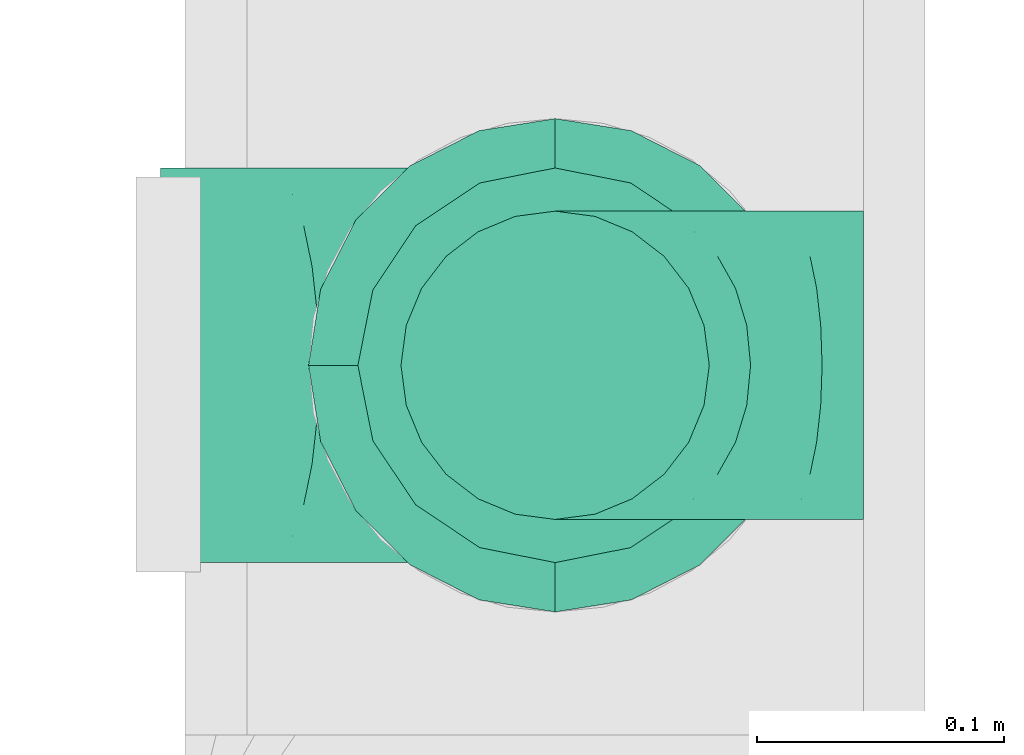
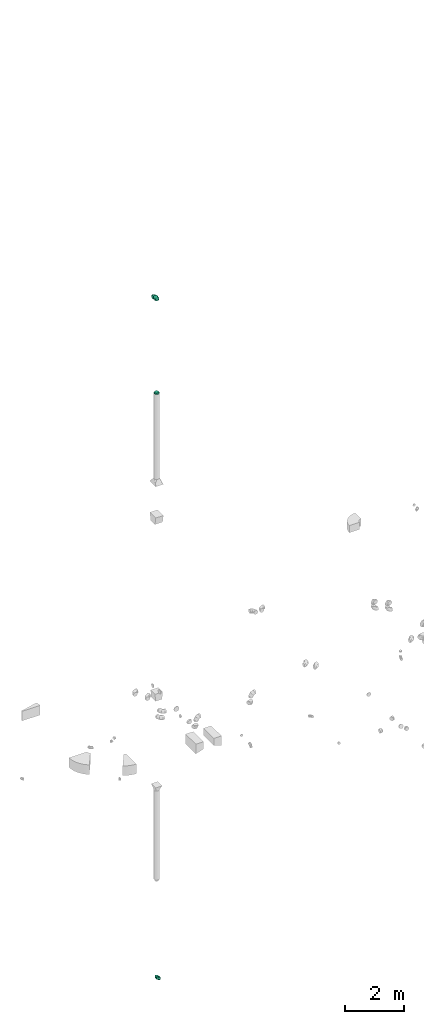
# One storey, part 4 of 32: 3 flow fittings.
"""IFC2X3 building model written with IfcOpenShell, lengths in millimetres."""

import ifcopenshell
import ifcopenshell.guid

model = None  # the IFC model being written
_history = None  # IfcOwnerHistory: only IFC2X3 demands one
_inside = {}  # id of a spatial element -> (the spatial element, [elements in it])
_under = {}  # id of a project, library or spatial element -> (it, [spatial elements below it])
_declared = {}  # id of a project -> (the project, [libraries it declares])
_typed = {}  # id of a type object -> (the type object, [elements of that type])
_made_of = {}  # id of a material, layer set ... -> (it, [elements and type objects made of it])


def new_model(schema):
    """Start an empty IFC model of exactly this schema.

    Asked for "IFC4X3", IfcOpenShell would pick the latest addendum, in which some entities
    have other attributes; the version numbers below select the first issue.
    IFC2X3 requires an IfcOwnerHistory on every rooted entity: one is made here for all.
    """
    global model, _history
    if schema == "IFC4X3":
        model = ifcopenshell.file(schema_version=(4, 3, 0, 0))
    else:
        model = ifcopenshell.file(schema=schema)
    _inside.clear()
    _under.clear()
    _declared.clear()
    _typed.clear()
    _made_of.clear()
    _history = None
    if model.schema == "IFC2X3":
        org = make("IfcOrganization", Name="unknown")
        user = make(
            "IfcPersonAndOrganization",
            ThePerson=make("IfcPerson", FamilyName="unknown"),
            TheOrganization=org,
        )
        app = make(
            "IfcApplication",
            ApplicationDeveloper=org,
            Version="unknown",
            ApplicationFullName="unknown",
            ApplicationIdentifier="unknown",
        )
        _history = make(
            "IfcOwnerHistory",
            OwningUser=user,
            OwningApplication=app,
            ChangeAction="ADDED",
            CreationDate=0,
        )
    return model


def make(cls, **values):
    """One entity of the class cls with the attributes given. An attribute that is None is left unset."""
    return model.create_entity(
        cls, **{name: value for name, value in values.items() if value is not None}
    )


def entity(cls, *values):
    """Any entity or typed value of the class cls, its attributes in the order of the schema. None: left unset."""
    e = model.create_entity(cls)
    for i, value in enumerate(values):
        if value is not None:
            e[i] = value
    return e


def rooted(cls, **values):
    """An entity with a GlobalId (a new one), such as an element, a storey or a relation."""
    return make(cls, GlobalId=ifcopenshell.guid.new(), OwnerHistory=_history, **values)


def si_unit(unit_type, name, prefix=None):
    """IfcSIUnit, for example si_unit("LENGTHUNIT", "METRE", prefix="MILLI")."""
    return make("IfcSIUnit", UnitType=unit_type, Prefix=prefix, Name=name)


def converted_unit(unit_type, name, factor, base, dimensions=None, offset=None):
    """IfcConversionBasedUnit, such as the inch: factor (a typed value) times the base unit."""
    return make(
        "IfcConversionBasedUnit"
        if offset is None
        else "IfcConversionBasedUnitWithOffset",
        ConversionOffset=offset,
        Dimensions=None
        if dimensions is None
        else entity("IfcDimensionalExponents", *dimensions),
        UnitType=unit_type,
        Name=name,
        ConversionFactor=make(
            "IfcMeasureWithUnit", ValueComponent=factor, UnitComponent=base
        ),
    )


def derived_unit(unit_type, elements):
    """IfcDerivedUnit: a product of units, each with its exponent."""
    return make(
        "IfcDerivedUnit",
        Elements=[
            make("IfcDerivedUnitElement", Unit=unit, Exponent=power)
            for unit, power in elements
        ],
        UnitType=unit_type,
    )


def assignment(units):
    """IfcUnitAssignment: the units of a project."""
    return None if units is None else make("IfcUnitAssignment", Units=units)


def point(xyz):
    """IfcCartesianPoint."""
    return None if xyz is None else make("IfcCartesianPoint", Coordinates=xyz)


def direction(xyz):
    """IfcDirection."""
    return None if xyz is None else make("IfcDirection", DirectionRatios=xyz)


def frame(location, z_axis=None, x_axis=None):
    """IfcAxis2Placement3D, a coordinate frame: its origin and axes. An axis left out is left unset."""
    return make(
        "IfcAxis2Placement3D",
        Location=point(location),
        Axis=direction(z_axis),
        RefDirection=direction(x_axis),
    )


def origin():
    """The frame at (0, 0, 0) with its axes left unset."""
    return frame((0.0, 0.0, 0.0))


def place(relative_to, where):
    """IfcLocalPlacement: puts the frame where relative to a parent placement (None: the world)."""
    return make(
        "IfcLocalPlacement", PlacementRelTo=relative_to, RelativePlacement=where
    )


def context(
    kind, dimensions, precision=None, world=None, true_north=None, identifier=None
):
    """IfcGeometricRepresentationContext, for example the 3D "Model" context."""
    return make(
        "IfcGeometricRepresentationContext",
        ContextIdentifier=identifier,
        ContextType=kind,
        CoordinateSpaceDimension=dimensions,
        Precision=precision,
        WorldCoordinateSystem=world,
        TrueNorth=true_north,
    )


def subcontext(parent, identifier, kind, view, scale=None):
    """IfcGeometricRepresentationSubContext, for example "Body" below "Model"."""
    return make(
        "IfcGeometricRepresentationSubContext",
        ContextIdentifier=identifier,
        ContextType=kind,
        ParentContext=parent,
        TargetScale=scale,
        TargetView=view,
    )


def project(units=None, contexts=None):
    """IfcProject with its units and contexts."""
    return rooted(
        "IfcProject",
        Name="project",
        RepresentationContexts=contexts,
        UnitsInContext=assignment(units),
    )


def spatial(cls, under=None, at=None, **own):
    """A site, building, storey or space (cls), placed at a placement, below another one or the project."""
    s = rooted(cls, ObjectPlacement=at, **own)
    if under is not None:
        _under.setdefault(under.id(), (under, []))[1].append(s)
    return s


def faces_of(points, faces, orient=None, outer=None):
    """IfcFace entities. A face is a list of loops; a loop is a list of indices into points, from 0.

    orient and outer hold one flag for each loop. By default every Orientation is true, the
    first loop of a face is its IfcFaceOuterBound and the others are IfcFaceBound.
    """
    made = []
    for i, loops in enumerate(faces):
        bounds = []
        for j, loop in enumerate(loops):
            is_outer = j == 0 if outer is None else outer[i][j]
            bounds.append(
                make(
                    "IfcFaceOuterBound" if is_outer else "IfcFaceBound",
                    Bound=make("IfcPolyLoop", Polygon=[points[k] for k in loop]),
                    Orientation=True if orient is None else orient[i][j],
                )
            )
        made.append(make("IfcFace", Bounds=bounds))
    return made


def faceted_brep(points, faces, orient=None, outer=None, voids=None):
    """IfcFacetedBrep: a solid bounded by flat faces; with voids (closed shells), ...WithVoids."""
    shared = [point(p) for p in points]
    hull = make("IfcClosedShell", CfsFaces=faces_of(shared, faces, orient, outer))
    if voids is None:
        return make("IfcFacetedBrep", Outer=hull)
    return make(
        "IfcFacetedBrepWithVoids",
        Outer=hull,
        Voids=[
            make(cls, CfsFaces=faces_of(shared, fs, o, b)) for cls, fs, o, b in voids
        ],
    )


def shape(context_of_items, identifier, shape_type, items):
    """IfcShapeRepresentation: the items that make up one representation, for example the "Body"."""
    return make(
        "IfcShapeRepresentation",
        ContextOfItems=context_of_items,
        RepresentationIdentifier=identifier,
        RepresentationType=shape_type,
        Items=items,
    )


def source(mapping_origin, context_of_items, identifier, shape_type, items):
    """IfcRepresentationMap: a shape defined once, which mapped items show again and again."""
    return make(
        "IfcRepresentationMap",
        MappingOrigin=mapping_origin,
        MappedRepresentation=shape(context_of_items, identifier, shape_type, items),
    )


def transform(
    local_origin,
    x_axis=None,
    y_axis=None,
    z_axis=None,
    scale=None,
    scale2=None,
    scale3=None,
    uniform=True,
):
    """IfcCartesianTransformationOperator3D, or its non-uniform kind. x_axis, y_axis, z_axis: its Axis1, 2, 3."""
    if uniform:
        return make(
            "IfcCartesianTransformationOperator3D",
            Axis1=direction(x_axis),
            Axis2=direction(y_axis),
            LocalOrigin=point(local_origin),
            Scale=scale,
            Axis3=direction(z_axis),
        )
    return make(
        "IfcCartesianTransformationOperator3DnonUniform",
        Axis1=direction(x_axis),
        Axis2=direction(y_axis),
        LocalOrigin=point(local_origin),
        Scale=scale,
        Axis3=direction(z_axis),
        Scale2=scale2,
        Scale3=scale3,
    )


def mapped(mapping_source, mapping_target):
    """IfcMappedItem: shows the shape of a source again, moved by a transform."""
    return make(
        "IfcMappedItem", MappingSource=mapping_source, MappingTarget=mapping_target
    )


def material(Name=None, Category=None):
    """IfcMaterial."""
    return make("IfcMaterial", Name=Name, Category=Category)


def made_of(thing, what):
    """Note that an element or type object is made of a material, layer set ...; save() writes the relation."""
    if what is not None:
        _made_of.setdefault(what.id(), (what, []))[1].append(thing)
    return thing


def type_object(cls, material=None, **own):
    """A type object (cls), such as IfcWallType, which elements share."""
    return made_of(rooted(cls, **own), material)


def type_shapes(of_type, sources):
    """Give a type object the sources (RepresentationMaps) that its elements show as mapped items."""
    of_type.RepresentationMaps = sources


def element(
    cls,
    number,
    at=None,
    inside=None,
    cuts=None,
    type_object=None,
    material=None,
    context=None,
    identifier="Body",
    shape_type=None,
    held_by="IfcProductDefinitionShape",
    body=None,
    shapes=None,
    **own,
):
    """One element of the class cls, such as IfcWall. Its Tag is "e" and its number.

    at: its placement. inside: the storey or other place that contains it. cuts: it is an
    opening in that element (IfcRelVoidsElement). A single representation is given by context,
    identifier, shape_type and body (its items); several are given by shapes. held_by: the class
    of the entity that holds the representations. save() writes the other relations.
    """
    e = rooted(cls, Tag="e%d" % number, ObjectPlacement=at, **own)
    if body is not None:
        shapes = [shape(context, identifier, shape_type, body)]
    if shapes is not None:
        e.Representation = make(held_by, Representations=shapes)
    if inside is not None:
        _inside.setdefault(inside.id(), (inside, []))[1].append(e)
    if cuts is not None:
        rooted(
            "IfcRelVoidsElement", RelatingBuildingElement=cuts, RelatedOpeningElement=e
        )
    if type_object is not None:
        _typed.setdefault(type_object.id(), (type_object, []))[1].append(e)
    return made_of(e, material)


def aggregate(whole, parts):
    """IfcRelAggregates: a whole, such as a stair, and the parts it consists of."""
    return rooted("IfcRelAggregates", RelatingObject=whole, RelatedObjects=parts)


def save(model, path):
    """Write the relations noted so far, then the file.

    IfcRelAggregates (storeys below a building ...), IfcRelContainedInSpatialStructure (elements
    in a storey), IfcRelDefinesByType, IfcRelAssociatesMaterial and IfcRelDeclares: one each for
    every whole, place, type object, material and project.
    """
    for whole, parts in _under.values():
        aggregate(whole, parts)
    for where, things in _inside.values():
        rooted(
            "IfcRelContainedInSpatialStructure",
            RelatedElements=things,
            RelatingStructure=where,
        )
    for kind, things in _typed.values():
        rooted("IfcRelDefinesByType", RelatedObjects=things, RelatingType=kind)
    for what, things in _made_of.values():
        rooted("IfcRelAssociatesMaterial", RelatedObjects=things, RelatingMaterial=what)
    for by, libraries in _declared.values():
        rooted("IfcRelDeclares", RelatingContext=by, RelatedDefinitions=libraries)
    model.write(path)


model = new_model("IFC2X3")

# Units and contexts
model_context = context("Model", 3, precision=0.01, world=origin(), true_north=direction((6.12303176911189e-17, 1.0)))
body_context = subcontext(model_context, "Body", "Model", "MODEL_VIEW")
ifc_project = project(units=[si_unit("LENGTHUNIT", "METRE", prefix="MILLI"), si_unit("AREAUNIT", "SQUARE_METRE"), si_unit("VOLUMEUNIT", "CUBIC_METRE"), converted_unit("PLANEANGLEUNIT", "DEGREE", entity("IfcRatioMeasure", 0.0174532925199433), si_unit("PLANEANGLEUNIT", "RADIAN"), dimensions=[0, 0, 0, 0, 0, 0, 0]), si_unit("MASSUNIT", "GRAM", prefix="KILO"), derived_unit("MASSDENSITYUNIT", [(si_unit("MASSUNIT", "GRAM", prefix="KILO"), 1), (si_unit("LENGTHUNIT", "METRE"), -3)]), derived_unit("MOMENTOFINERTIAUNIT", [(si_unit("LENGTHUNIT", "METRE"), 4)]), si_unit("TIMEUNIT", "SECOND"), si_unit("FREQUENCYUNIT", "HERTZ"), si_unit("THERMODYNAMICTEMPERATUREUNIT", "DEGREE_CELSIUS"), derived_unit("THERMALTRANSMITTANCEUNIT", [(si_unit("MASSUNIT", "GRAM", prefix="KILO"), 1), (si_unit("THERMODYNAMICTEMPERATUREUNIT", "KELVIN"), -1), (si_unit("TIMEUNIT", "SECOND"), -3)]), derived_unit("VOLUMETRICFLOWRATEUNIT", [(si_unit("LENGTHUNIT", "METRE"), 3), (si_unit("TIMEUNIT", "SECOND"), -1)]), derived_unit("MASSFLOWRATEUNIT", [(si_unit("MASSUNIT", "GRAM", prefix="KILO"), 1), (si_unit("TIMEUNIT", "SECOND"), -1)]), derived_unit("ROTATIONALFREQUENCYUNIT", [(si_unit("TIMEUNIT", "SECOND"), -1)]), si_unit("ELECTRICCURRENTUNIT", "AMPERE"), si_unit("ELECTRICVOLTAGEUNIT", "VOLT"), si_unit("POWERUNIT", "WATT"), si_unit("FORCEUNIT", "NEWTON", prefix="KILO"), si_unit("ILLUMINANCEUNIT", "LUX"), si_unit("LUMINOUSFLUXUNIT", "LUMEN"), si_unit("LUMINOUSINTENSITYUNIT", "CANDELA"), derived_unit("USERDEFINED", [(si_unit("MASSUNIT", "GRAM", prefix="KILO"), -1), (si_unit("LENGTHUNIT", "METRE"), -2), (si_unit("TIMEUNIT", "SECOND"), 3), (si_unit("LUMINOUSFLUXUNIT", "LUMEN"), 1)]), derived_unit("LINEARVELOCITYUNIT", [(si_unit("LENGTHUNIT", "METRE"), 1), (si_unit("TIMEUNIT", "SECOND"), -1)]), si_unit("PRESSUREUNIT", "PASCAL"), derived_unit("USERDEFINED", [(si_unit("LENGTHUNIT", "METRE"), -2), (si_unit("MASSUNIT", "GRAM", prefix="KILO"), 1), (si_unit("TIMEUNIT", "SECOND"), -2)]), derived_unit("LINEARFORCEUNIT", [(si_unit("MASSUNIT", "GRAM", prefix="KILO"), 1), (si_unit("LENGTHUNIT", "METRE"), 1), (si_unit("TIMEUNIT", "SECOND"), -2), (si_unit("LENGTHUNIT", "METRE"), -1)]), derived_unit("PLANARFORCEUNIT", [(si_unit("MASSUNIT", "GRAM", prefix="KILO"), 1), (si_unit("LENGTHUNIT", "METRE"), 1), (si_unit("TIMEUNIT", "SECOND"), -2), (si_unit("LENGTHUNIT", "METRE"), -2)])], contexts=[model_context])

# Site, building, storey
site_placement = place(None, origin())
site = spatial("IfcSite", under=ifc_project, at=site_placement, CompositionType="ELEMENT")
building_placement = place(site_placement, origin())
building = spatial("IfcBuilding", under=site, at=building_placement, CompositionType="ELEMENT")
storey_placement = place(building_placement, frame((0.0, 0.0, 8100.0)))
storey = spatial("IfcBuildingStorey", under=building, at=storey_placement, CompositionType="ELEMENT", Elevation=8100.0)

# Flow fittings
ifc_material = material()
duct_fitting_type_1 = type_object("IfcDuctFittingType", PredefinedType="NOTDEFINED", material=ifc_material)
shared_shape_1 = source(origin(), body_context, "Body", "Brep", [
    faceted_brep([(-160.0, 0.0, -80.0), (-160.0, -20.71, -77.27), (-160.0, -40.0, -69.28), (-160.0, -56.57, -56.57), (-160.0, -69.28, -40.0), (-160.0, -77.27, -20.71), (-160.0, -80.0, 0.0), (-160.0, -77.27, 20.71), (-160.0, -69.28, 40.0), (-160.0, -56.57, 56.57), (-160.0, -40.0, 69.28), (-160.0, -20.71, 77.27), (-160.0, 0.0, 80.0), (-160.0, 20.71, 77.27), (-160.0, 40.0, 69.28), (-160.0, 56.57, 56.57), (-160.0, 69.28, 40.0), (-160.0, 77.27, 20.71), (-160.0, 80.0, 0.0), (-160.0, 77.27, -20.71), (-160.0, 69.28, -40.0), (-160.0, 56.57, -56.57), (-160.0, 40.0, -69.28), (-160.0, 20.71, -77.27), (-122.68, 20.71, 77.27), (-127.85, 40.0, 69.28), (-117.13, 0.0, 80.0), (-132.29, 56.57, 56.57), (-137.83, 77.27, 20.71), (-138.56, 80.0, 0.0), (-135.69, 69.28, 40.0), (-135.69, 69.28, -40.0), (-132.29, 56.57, -56.57), (-137.83, 77.27, -20.71), (-122.68, 20.71, -77.27), (-117.13, 0.0, -80.0), (-127.85, 40.0, -69.28), (-111.58, -20.71, -77.27), (-106.41, -40.0, -69.28), (-101.97, -56.57, -56.57), (-98.56, -69.28, -40.0), (-96.42, -77.27, -20.71), (-95.69, -80.0, 0.0), (-96.42, -77.27, 20.71), (-98.56, -69.28, 40.0), (-101.97, -56.57, 56.57), (-106.41, -40.0, 69.28), (-111.58, -20.71, 77.27), (-58.03, 58.03, 77.27), (-72.15, 72.15, 69.28), (-42.87, 42.87, 80.0), (-84.28, 84.28, 56.57), (-93.59, 93.59, 40.0), (-99.44, 99.44, 20.71), (-101.44, 101.44, 0.0), (-99.44, 99.44, -20.71), (-93.59, 93.59, -40.0), (-84.28, 84.28, -56.57), (-58.03, 58.03, -77.27), (-42.87, 42.87, -80.0), (-72.15, 72.15, -69.28), (-27.71, 27.71, -77.27), (-13.59, 13.59, -69.28), (-1.46, 1.46, -56.57), (7.85, -7.85, -40.0), (13.7, -13.7, -20.71), (15.69, -15.69, 0.0), (13.7, -13.7, 20.71), (7.85, -7.85, 40.0), (-1.46, 1.46, 56.57), (-13.59, 13.59, 69.28), (-27.71, 27.71, 77.27), (-20.71, 122.68, 77.27), (-40.0, 127.85, 69.28), (0.0, 117.13, 80.0), (-56.57, 132.29, 56.57), (-69.28, 135.69, 40.0), (-77.27, 137.83, 20.71), (-80.0, 138.56, 0.0), (-77.27, 137.83, -20.71), (-69.28, 135.69, -40.0), (-56.57, 132.29, -56.57), (-20.71, 122.68, -77.27), (0.0, 117.13, -80.0), (-40.0, 127.85, -69.28), (20.71, 111.58, -77.27), (40.0, 106.41, -69.28), (56.57, 101.97, -56.57), (69.28, 98.56, -40.0), (77.27, 96.42, -20.71), (80.0, 95.69, 0.0), (77.27, 96.42, 20.71), (69.28, 98.56, 40.0), (56.57, 101.97, 56.57), (40.0, 106.41, 69.28), (20.71, 111.58, 77.27), (-20.71, 160.0, -77.27), (-40.0, 160.0, -69.28), (-56.57, 160.0, -56.57), (-69.28, 160.0, -40.0), (-77.27, 160.0, -20.71), (-80.0, 160.0, 0.0), (-77.27, 160.0, 20.71), (-69.28, 160.0, 40.0), (-56.57, 160.0, 56.57), (-40.0, 160.0, 69.28), (-20.71, 160.0, 77.27), (0.0, 160.0, 80.0), (20.71, 160.0, 77.27), (40.0, 160.0, 69.28), (56.57, 160.0, 56.57), (69.28, 160.0, 40.0), (77.27, 160.0, 20.71), (80.0, 160.0, 0.0), (77.27, 160.0, -20.71), (69.28, 160.0, -40.0), (56.57, 160.0, -56.57), (40.0, 160.0, -69.28), (20.71, 160.0, -77.27), (0.0, 160.0, -80.0)], [[[0, 1, 2, 3, 4, 5, 6, 7, 8, 9, 10, 11, 12, 13, 14, 15, 16, 17, 18, 19, 20, 21, 22, 23]], [[24, 25, 14, 13]], [[26, 24, 13, 12]], [[14, 25, 27, 15]], [[28, 29, 18, 17]], [[30, 28, 17, 16]], [[15, 27, 30, 16]], [[20, 31, 32, 21]], [[33, 31, 20, 19]], [[18, 29, 33, 19]], [[34, 35, 0, 23]], [[36, 34, 23, 22]], [[32, 36, 22, 21]], [[1, 0, 35, 37]], [[2, 1, 37, 38]], [[3, 2, 38, 39]], [[5, 4, 40, 41]], [[6, 5, 41, 42]], [[39, 40, 4, 3]], [[6, 42, 43, 7]], [[7, 43, 44, 8]], [[8, 44, 45, 9]], [[9, 45, 46, 10]], [[10, 46, 47, 11]], [[26, 12, 11, 47]], [[48, 49, 25, 24]], [[50, 48, 24, 26]], [[27, 25, 49, 51]], [[52, 53, 28, 30]], [[51, 52, 30, 27]], [[29, 28, 53, 54]], [[55, 56, 31, 33]], [[54, 55, 33, 29]], [[32, 31, 56, 57]], [[58, 59, 35, 34]], [[60, 58, 34, 36]], [[57, 60, 36, 32]], [[37, 35, 59, 61]], [[38, 37, 61, 62]], [[39, 38, 62, 63]], [[41, 40, 64, 65]], [[42, 41, 65, 66]], [[63, 64, 40, 39]], [[43, 42, 66, 67]], [[44, 43, 67, 68]], [[68, 69, 45, 44]], [[46, 45, 69, 70]], [[47, 46, 70, 71]], [[26, 47, 71, 50]], [[72, 73, 49, 48]], [[74, 72, 48, 50]], [[51, 49, 73, 75]], [[76, 77, 53, 52]], [[75, 76, 52, 51]], [[54, 53, 77, 78]], [[79, 80, 56, 55]], [[78, 79, 55, 54]], [[57, 56, 80, 81]], [[82, 83, 59, 58]], [[84, 82, 58, 60]], [[81, 84, 60, 57]], [[61, 59, 83, 85]], [[62, 61, 85, 86]], [[63, 62, 86, 87]], [[65, 64, 88, 89]], [[66, 65, 89, 90]], [[87, 88, 64, 63]], [[67, 66, 90, 91]], [[68, 67, 91, 92]], [[92, 93, 69, 68]], [[70, 69, 93, 94]], [[71, 70, 94, 95]], [[50, 71, 95, 74]], [[96, 97, 98, 99, 100, 101, 102, 103, 104, 105, 106, 107, 108, 109, 110, 111, 112, 113, 114, 115, 116, 117, 118, 119]], [[72, 74, 107, 106]], [[73, 72, 106, 105]], [[75, 73, 105, 104]], [[77, 76, 103, 102]], [[78, 77, 102, 101]], [[75, 104, 103, 76]], [[78, 101, 100, 79]], [[79, 100, 99, 80]], [[80, 99, 98, 81]], [[84, 97, 96, 82]], [[82, 96, 119, 83]], [[84, 81, 98, 97]], [[118, 117, 86, 85]], [[119, 118, 85, 83]], [[116, 87, 86, 117]], [[88, 115, 114, 89]], [[89, 114, 113, 90]], [[115, 88, 87, 116]], [[112, 111, 92, 91]], [[113, 112, 91, 90]], [[111, 110, 93, 92]], [[95, 94, 109, 108]], [[74, 95, 108, 107]], [[110, 109, 94, 93]]]),
])
type_shapes(duct_fitting_type_1, [shared_shape_1])
flow_fitting_1_placement = place(storey_placement, frame((8023.56, 14800.47, 19500.0), z_axis=(0.0, -1.0, 0.0), x_axis=(0.0, 0.0, 1.0)))
element("IfcFlowFitting", 1, at=flow_fitting_1_placement, inside=storey, type_object=duct_fitting_type_1, material=ifc_material, context=body_context, shape_type="MappedRepresentation", body=[
    mapped(shared_shape_1, transform((0.0, 0.0, 0.0), scale=1.0)),
])
duct_fitting_type_2 = type_object("IfcDuctFittingType", PredefinedType="NOTDEFINED", material=ifc_material)
shared_shape_2 = source(origin(), body_context, "Body", "Brep", [
    faceted_brep([(-125.0, 0.0, -62.5), (-125.0, -16.18, -60.37), (-125.0, -31.25, -54.13), (-125.0, -44.19, -44.19), (-125.0, -54.13, -31.25), (-125.0, -60.37, -16.18), (-125.0, -62.5, 0.0), (-125.0, -60.37, 16.18), (-125.0, -54.13, 31.25), (-125.0, -44.19, 44.19), (-125.0, -31.25, 54.13), (-125.0, -16.18, 60.37), (-125.0, 0.0, 62.5), (-125.0, 16.18, 60.37), (-125.0, 31.25, 54.13), (-125.0, 44.19, 44.19), (-125.0, 54.13, 31.25), (-125.0, 60.37, 16.18), (-125.0, 62.5, 0.0), (-125.0, 60.37, -16.18), (-125.0, 54.13, -31.25), (-125.0, 44.19, -44.19), (-125.0, 31.25, -54.13), (-125.0, 16.18, -60.37), (-95.84, 16.18, 60.37), (-99.88, 31.25, 54.13), (-91.51, 0.0, 62.5), (-103.35, 44.19, 44.19), (-107.68, 60.37, 16.18), (-108.25, 62.5, 0.0), (-106.01, 54.13, 31.25), (-106.01, 54.13, -31.25), (-103.35, 44.19, -44.19), (-107.68, 60.37, -16.18), (-95.84, 16.18, -60.37), (-91.51, 0.0, -62.5), (-99.88, 31.25, -54.13), (-87.17, -16.18, -60.37), (-83.13, -31.25, -54.13), (-79.66, -44.19, -44.19), (-77.0, -54.13, -31.25), (-75.33, -60.37, -16.18), (-74.76, -62.5, 0.0), (-75.33, -60.37, 16.18), (-77.0, -54.13, 31.25), (-79.66, -44.19, 44.19), (-83.13, -31.25, 54.13), (-87.17, -16.18, 60.37), (-45.34, 45.34, 60.37), (-56.37, 56.37, 54.13), (-33.49, 33.49, 62.5), (-65.85, 65.85, 44.19), (-73.12, 73.12, 31.25), (-77.69, 77.69, 16.18), (-79.25, 79.25, 0.0), (-77.69, 77.69, -16.18), (-73.12, 73.12, -31.25), (-65.85, 65.85, -44.19), (-45.34, 45.34, -60.37), (-33.49, 33.49, -62.5), (-56.37, 56.37, -54.13), (-21.65, 21.65, -60.37), (-10.62, 10.62, -54.13), (-1.14, 1.14, -44.19), (6.13, -6.13, -31.25), (10.7, -10.7, -16.18), (12.26, -12.26, 0.0), (10.7, -10.7, 16.18), (6.13, -6.13, 31.25), (-1.14, 1.14, 44.19), (-10.62, 10.62, 54.13), (-21.65, 21.65, 60.37), (-16.18, 95.84, 60.37), (-31.25, 99.88, 54.13), (0.0, 91.51, 62.5), (-44.19, 103.35, 44.19), (-54.13, 106.01, 31.25), (-60.37, 107.68, 16.18), (-62.5, 108.25, 0.0), (-60.37, 107.68, -16.18), (-54.13, 106.01, -31.25), (-44.19, 103.35, -44.19), (-16.18, 95.84, -60.37), (0.0, 91.51, -62.5), (-31.25, 99.88, -54.13), (16.18, 87.17, -60.37), (31.25, 83.13, -54.13), (44.19, 79.66, -44.19), (54.13, 77.0, -31.25), (60.37, 75.33, -16.18), (62.5, 74.76, 0.0), (60.37, 75.33, 16.18), (54.13, 77.0, 31.25), (44.19, 79.66, 44.19), (31.25, 83.13, 54.13), (16.18, 87.17, 60.37), (-16.18, 125.0, -60.37), (-31.25, 125.0, -54.13), (-44.19, 125.0, -44.19), (-54.13, 125.0, -31.25), (-60.37, 125.0, -16.18), (-62.5, 125.0, 0.0), (-60.37, 125.0, 16.18), (-54.13, 125.0, 31.25), (-44.19, 125.0, 44.19), (-31.25, 125.0, 54.13), (-16.18, 125.0, 60.37), (0.0, 125.0, 62.5), (16.18, 125.0, 60.37), (31.25, 125.0, 54.13), (44.19, 125.0, 44.19), (54.13, 125.0, 31.25), (60.37, 125.0, 16.18), (62.5, 125.0, 0.0), (60.37, 125.0, -16.18), (54.13, 125.0, -31.25), (44.19, 125.0, -44.19), (31.25, 125.0, -54.13), (16.18, 125.0, -60.37), (0.0, 125.0, -62.5)], [[[0, 1, 2, 3, 4, 5, 6, 7, 8, 9, 10, 11, 12, 13, 14, 15, 16, 17, 18, 19, 20, 21, 22, 23]], [[24, 25, 14, 13]], [[26, 24, 13, 12]], [[14, 25, 27, 15]], [[28, 29, 18, 17]], [[30, 28, 17, 16]], [[15, 27, 30, 16]], [[20, 31, 32, 21]], [[33, 31, 20, 19]], [[18, 29, 33, 19]], [[34, 35, 0, 23]], [[36, 34, 23, 22]], [[21, 32, 36, 22]], [[1, 0, 35, 37]], [[2, 1, 37, 38]], [[38, 39, 3, 2]], [[5, 4, 40, 41]], [[6, 5, 41, 42]], [[39, 40, 4, 3]], [[6, 42, 43, 7]], [[7, 43, 44, 8]], [[45, 9, 8, 44]], [[9, 45, 46, 10]], [[10, 46, 47, 11]], [[26, 12, 11, 47]], [[48, 49, 25, 24]], [[50, 48, 24, 26]], [[27, 25, 49, 51]], [[52, 53, 28, 30]], [[51, 52, 30, 27]], [[29, 28, 53, 54]], [[55, 56, 31, 33]], [[54, 55, 33, 29]], [[57, 32, 31, 56]], [[58, 59, 35, 34]], [[60, 58, 34, 36]], [[57, 60, 36, 32]], [[37, 35, 59, 61]], [[38, 37, 61, 62]], [[39, 38, 62, 63]], [[41, 40, 64, 65]], [[42, 41, 65, 66]], [[63, 64, 40, 39]], [[43, 42, 66, 67]], [[44, 43, 67, 68]], [[68, 69, 45, 44]], [[46, 45, 69, 70]], [[47, 46, 70, 71]], [[26, 47, 71, 50]], [[72, 73, 49, 48]], [[74, 72, 48, 50]], [[51, 49, 73, 75]], [[76, 77, 53, 52]], [[75, 76, 52, 51]], [[54, 53, 77, 78]], [[79, 80, 56, 55]], [[78, 79, 55, 54]], [[81, 57, 56, 80]], [[82, 83, 59, 58]], [[84, 82, 58, 60]], [[81, 84, 60, 57]], [[61, 59, 83, 85]], [[62, 61, 85, 86]], [[63, 62, 86, 87]], [[65, 64, 88, 89]], [[66, 65, 89, 90]], [[87, 88, 64, 63]], [[67, 66, 90, 91]], [[68, 67, 91, 92]], [[92, 93, 69, 68]], [[70, 69, 93, 94]], [[71, 70, 94, 95]], [[50, 71, 95, 74]], [[96, 97, 98, 99, 100, 101, 102, 103, 104, 105, 106, 107, 108, 109, 110, 111, 112, 113, 114, 115, 116, 117, 118, 119]], [[72, 74, 107, 106]], [[73, 72, 106, 105]], [[75, 73, 105, 104]], [[77, 76, 103, 102]], [[78, 77, 102, 101]], [[75, 104, 103, 76]], [[78, 101, 100, 79]], [[79, 100, 99, 80]], [[80, 99, 98, 81]], [[96, 119, 83, 82]], [[97, 96, 82, 84]], [[84, 81, 98, 97]], [[83, 119, 118, 85]], [[85, 118, 117, 86]], [[116, 87, 86, 117]], [[88, 115, 114, 89]], [[89, 114, 113, 90]], [[115, 88, 87, 116]], [[91, 90, 113, 112]], [[92, 91, 112, 111]], [[111, 110, 93, 92]], [[95, 94, 109, 108]], [[74, 95, 108, 107]], [[110, 109, 94, 93]]]),
])
type_shapes(duct_fitting_type_2, [shared_shape_2])
flow_fitting_2_placement = place(storey_placement, frame((8023.54, 14800.47, -8900.0), z_axis=(0.0, -1.0, 0.0), x_axis=(0.0, 0.0, -1.0)))
element("IfcFlowFitting", 2, at=flow_fitting_2_placement, inside=storey, type_object=duct_fitting_type_2, material=ifc_material, context=body_context, shape_type="MappedRepresentation", body=[
    mapped(shared_shape_2, transform((0.0, 0.0, 0.0), scale=1.0)),
])
duct_fitting_type_3 = type_object("IfcDuctFittingType", PredefinedType="NOTDEFINED", material=ifc_material)
shared_shape_3 = source(origin(), body_context, "Body", "Brep", [
    faceted_brep([(40.0, -73.91, 30.61), (40.0, -76.96, 15.31), (40.0, -80.0, 0.0), (40.0, -76.96, -15.31), (40.0, -73.91, -30.61), (40.0, -65.24, -43.59), (40.0, -56.57, -56.57), (40.0, -43.59, -65.24), (40.0, -30.61, -73.91), (40.0, -15.31, -76.96), (40.0, 0.0, -80.0), (40.0, 15.31, -76.96), (40.0, 30.61, -73.91), (40.0, 43.59, -65.24), (40.0, 56.57, -56.57), (40.0, 65.24, -43.59), (40.0, 73.91, -30.61), (40.0, 76.96, -15.31), (40.0, 80.0, 0.0), (40.0, 76.96, 15.31), (40.0, 73.91, 30.61), (40.0, 65.24, 43.59), (40.0, 56.57, 56.57), (40.0, 43.59, 65.24), (40.0, 30.61, 73.91), (40.0, 15.31, 76.96), (40.0, 0.0, 80.0), (40.0, -15.31, 76.96), (40.0, -30.61, 73.91), (40.0, -43.59, 65.24), (40.0, -56.57, 56.57), (40.0, -65.24, 43.59), (0.0, -100.0, 0.0), (0.0, -95.11, 30.9), (0.0, -80.9, 58.78), (0.0, -58.78, 80.9), (0.0, -30.9, 95.11), (0.0, 0.0, 100.0), (0.0, 30.9, 95.11), (0.0, 58.78, 80.9), (0.0, 80.9, 58.78), (0.0, 95.11, 30.9), (0.0, 100.0, 0.0), (0.0, 95.11, -30.9), (0.0, 80.9, -58.78), (0.0, 58.78, -80.9), (0.0, 30.9, -95.11), (0.0, 0.0, -100.0), (0.0, -30.9, -95.11), (0.0, -58.78, -80.9), (0.0, -80.9, -58.78), (0.0, -95.11, -30.9)], [[[0, 1, 2, 3, 4, 5, 6, 7, 8, 9, 10, 11, 12, 13, 14, 15, 16, 17, 18, 19, 20, 21, 22, 23, 24, 25, 26, 27, 28, 29, 30, 31]], [[32, 33, 34, 35, 36, 37, 38, 39, 40, 41, 42, 43, 44, 45, 46, 47, 48, 49, 50, 51]], [[37, 25, 38]], [[25, 24, 38]], [[24, 39, 38]], [[41, 20, 19]], [[25, 37, 26]], [[39, 24, 23, 22]], [[42, 19, 18]], [[20, 40, 22, 21]], [[41, 40, 20]], [[42, 41, 19]], [[22, 40, 39]], [[32, 1, 33]], [[1, 0, 33]], [[0, 34, 33]], [[36, 28, 27]], [[1, 32, 2]], [[34, 0, 31, 30]], [[37, 27, 26]], [[28, 35, 30, 29]], [[36, 35, 28]], [[37, 36, 27]], [[30, 35, 34]], [[47, 9, 48]], [[9, 8, 48]], [[8, 49, 48]], [[51, 4, 3]], [[9, 47, 10]], [[49, 8, 7, 6]], [[32, 3, 2]], [[4, 50, 6, 5]], [[51, 50, 4]], [[32, 51, 3]], [[6, 50, 49]], [[42, 17, 43]], [[17, 16, 43]], [[16, 44, 43]], [[46, 12, 11]], [[17, 42, 18]], [[44, 16, 15, 14]], [[47, 11, 10]], [[12, 45, 14, 13]], [[46, 45, 12]], [[47, 46, 11]], [[14, 45, 44]]]),
])
type_shapes(duct_fitting_type_3, [shared_shape_3])
flow_fitting_3_placement = place(storey_placement, frame((8023.56, 14800.47, 15460.0), z_axis=(-1.0, 0.0, 0.0), x_axis=(0.0, 0.0, 1.0)))
element("IfcFlowFitting", 3, at=flow_fitting_3_placement, inside=storey, type_object=duct_fitting_type_3, material=ifc_material, context=body_context, shape_type="MappedRepresentation", body=[
    mapped(shared_shape_3, transform((0.0, 0.0, 0.0), scale=1.0)),
])

save(model, "model.ifc")
